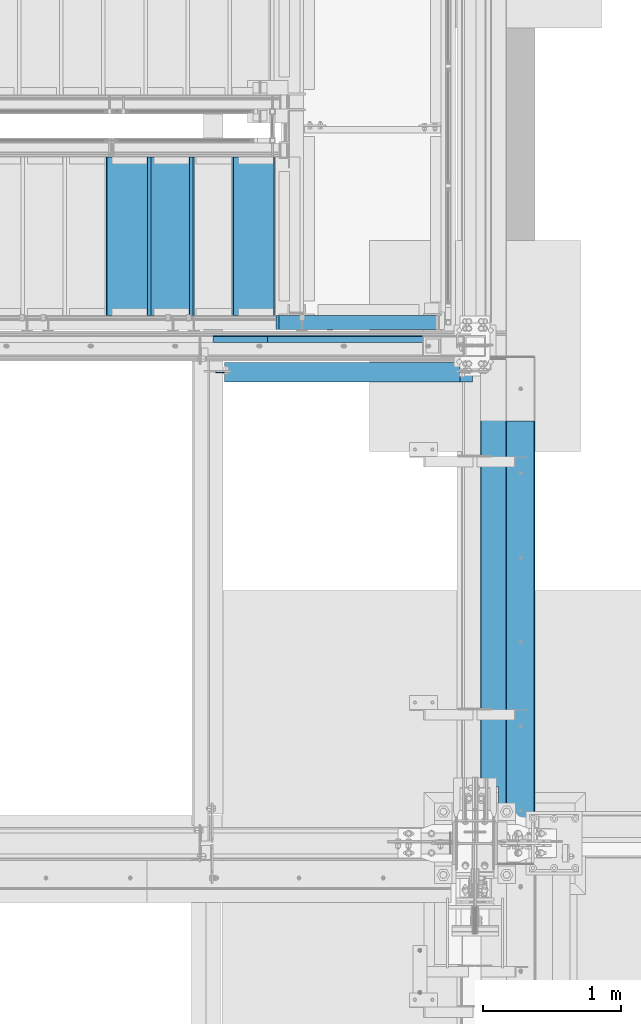
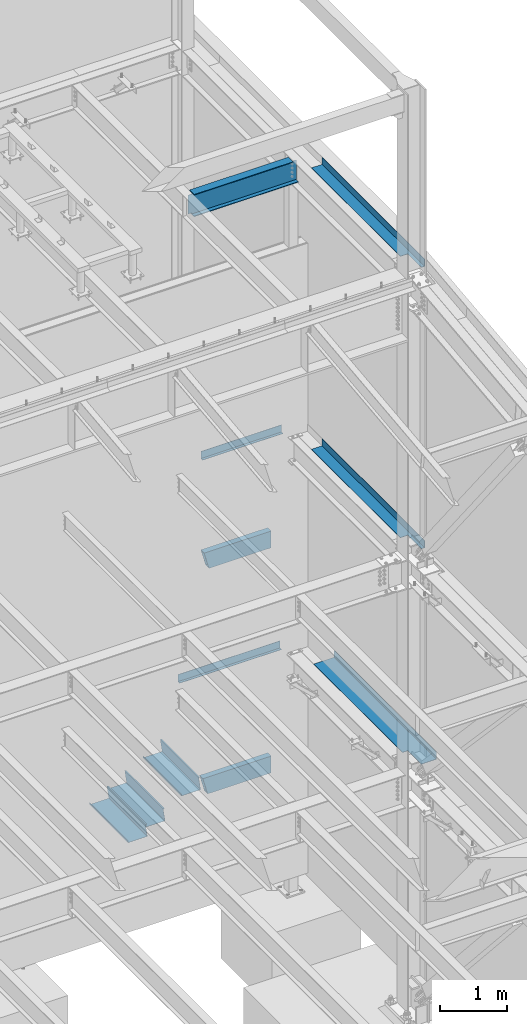
# One storey, part 785 of 1179: 11 beams, 8 elements without a shape of their own.
"""IFC2X3 building model written with IfcOpenShell, lengths in millimetres."""

from ifc_helpers import new_model, si_unit, frame, origin_with_axes, place, context, subcontext, project, spatial, faceted_brep, material, type_object, element, aggregate, save


model = new_model("IFC2X3")

# Units and contexts
model_context = context("Model", 3, precision=1e-05, world=origin_with_axes())
body_context = subcontext(model_context, "Body", "Model", "MODEL_VIEW")
ifc_project = project(units=[si_unit("LENGTHUNIT", "METRE", prefix="MILLI"), si_unit("AREAUNIT", "SQUARE_METRE"), si_unit("VOLUMEUNIT", "CUBIC_METRE"), si_unit("MASSUNIT", "GRAM", prefix="KILO"), si_unit("TIMEUNIT", "SECOND"), si_unit("PLANEANGLEUNIT", "RADIAN"), si_unit("SOLIDANGLEUNIT", "STERADIAN"), si_unit("THERMODYNAMICTEMPERATUREUNIT", "DEGREE_CELSIUS"), si_unit("LUMINOUSINTENSITYUNIT", "LUMEN")], contexts=[model_context])

# Site, building, storey
site_placement = place(None, origin_with_axes())
site = spatial("IfcSite", under=ifc_project, at=site_placement, CompositionType="ELEMENT")
building_placement = place(site_placement, origin_with_axes())
building = spatial("IfcBuilding", under=site, at=building_placement, Name="Undefined", CompositionType="ELEMENT")
storey_placement = place(building_placement, origin_with_axes())
storey = spatial("IfcBuildingStorey", under=building, at=storey_placement, Name="Undefined", CompositionType="ELEMENT", Elevation=0.0)

# Assembly, beam
assembly_1_placement = place(storey_placement, origin_with_axes())
assembly_1 = element("IfcElementAssembly", 1, at=assembly_1_placement, inside=storey, Name="BEAM", AssemblyPlace="NOTDEFINED", PredefinedType="RIGID_FRAME")
ifc_material_1 = material(Name="STEEL/A36")
beam_type_1 = type_object("IfcBeamType", PredefinedType="NOTDEFINED")
beam_1_placement = place(assembly_1_placement, frame((23498.175, 38058.725, 8147.05000610352), z_axis=(1.0, 0.0, 0.0), x_axis=(0.0, 0.0, -1.0)))
beam_1 = element("IfcBeam", 2, at=beam_1_placement, type_object=beam_type_1, material=ifc_material_1, Name="BENT_PLATE", context=body_context, shape_type="Brep", body=[
    faceted_brep([(0.0, -3.17500000000291, -688.974999999999), (0.0, -3.17500000000291, 688.974999999999), (0.0, 3.17500000000291, 688.974999999999), (0.0, 3.17500000000291, -688.974999999999), (133.350006103513, 3.17500000000291, 688.974999999999), (133.350006103513, 3.17500000000291, -688.974999999999), (127.000006103513, -3.17500000000291, -688.974999999999), (127.000006103513, -3.17500000000291, 688.974999999999), (133.350006103513, -47.6249999999927, 688.974999999999), (133.350006103513, -47.6249999999927, -688.974999999999), (127.000006103513, -47.6249999999927, 688.974999999999), (127.000006103513, -47.6249999999927, -688.974999999999)], [[[0, 1, 2, 3]], [[3, 2, 4, 5]], [[1, 0, 6, 7]], [[5, 4, 8, 9]], [[4, 2, 1, 7, 10, 8]], [[7, 6, 11, 10]], [[6, 0, 3, 5, 9, 11]], [[10, 11, 9, 8]]]),
])
aggregate(assembly_1, [beam_1])

assembly_2_placement = place(storey_placement, origin_with_axes())
assembly_2 = element("IfcElementAssembly", 3, at=assembly_2_placement, inside=storey, Name="BEAM", AssemblyPlace="NOTDEFINED", PredefinedType="RIGID_FRAME")
beam_2_placement = place(assembly_2_placement, frame((23290.2125, 38058.725, 4235.45000610352), z_axis=(1.0, 0.0, 0.0), x_axis=(0.0, 0.0, -1.0)))
beam_2 = element("IfcBeam", 4, at=beam_2_placement, type_object=beam_type_1, material=ifc_material_1, Name="BENT_PLATE", context=body_context, shape_type="Brep", body=[
    faceted_brep([(0.0, -3.17500000000291, -874.712500000001), (0.0, -3.17500000000291, 874.712500000001), (0.0, 3.17500000000291, 874.712500000001), (0.0, 3.17500000000291, -874.712500000001), (133.350006103513, 3.17500000000291, 874.712500000001), (133.350006103513, 3.17500000000291, -874.712500000001), (127.000006103513, -3.17500000000291, -874.712500000001), (127.000006103513, -3.17500000000291, 874.712500000001), (133.350006103513, -47.6249999999927, 874.712500000001), (133.350006103513, -47.6249999999927, -874.712500000001), (127.000006103513, -47.6249999999927, 874.712500000001), (127.000006103513, -47.6249999999927, -874.712500000001)], [[[0, 1, 2, 3]], [[3, 2, 4, 5]], [[1, 0, 6, 7]], [[5, 4, 8, 9]], [[4, 2, 1, 7, 10, 8]], [[7, 6, 11, 10]], [[6, 0, 3, 5, 9, 11]], [[10, 11, 9, 8]]]),
])
aggregate(assembly_2, [beam_2])

assembly_3_placement = place(storey_placement, origin_with_axes())
assembly_3 = element("IfcElementAssembly", 5, at=assembly_3_placement, inside=storey, Name="BEAM", AssemblyPlace="NOTDEFINED", PredefinedType="RIGID_FRAME")
ifc_material_2 = material(Name="STEEL/A992")
beam_type_2 = type_object("IfcBeamType", Name="W16X31", PredefinedType="NOTDEFINED")
beam_3_placement = place(assembly_3_placement, frame((22415.5, 37795.2, 12917.4875), z_axis=(0.0, 0.0, 1.0), x_axis=(1.0, 0.0, 0.0)))
beam_3 = element("IfcBeam", 6, at=beam_3_placement, type_object=beam_type_2, material=ifc_material_2, Name="BEAM", ObjectType="W16X31", context=body_context, shape_type="Brep", body=[
    faceted_brep([(1781.96875, -69.8499999999985, 201.612499999999), (1781.96875, -69.8499999999985, 190.5), (1781.96875, -3.17500000000291, 190.5), (1781.96875, -3.17500000000291, 176.212499809264), (1781.96875, 3.17500000000291, 176.212499809264), (1781.96875, 3.17500000000291, 190.5), (1781.96875, 69.8499999999985, 190.5), (1781.96875, 69.8499999999985, 201.612499999999), (1782.93547992258, -3.17500000000291, 171.352420291218), (1782.93547992258, 3.17500000000291, 171.352420291218), (1785.68849382306, -3.17500000000291, 167.232243823064), (1785.68849382306, 3.17500000000291, 167.232243823064), (1789.80867029122, -3.17500000000291, 164.479229922586), (1789.80867029122, 3.17500000000291, 164.479229922586), (1794.66874980926, -3.17500000000291, 163.512499999999), (1794.66874980926, 3.17500000000291, 163.512499999999), (1874.04375, -3.17500000000291, 163.512499999999), (1874.04375, 3.17500000000291, 163.512499999999), (82.549999999992, -69.8499999999985, 201.6125), (82.549999999992, 69.8499999999985, 201.6125), (82.549999999992, 69.8499999999985, 190.5), (82.549999999992, 3.17499999999927, 190.5), (82.549999999992, 3.17499999999927, 182.562499809265), (82.549999999992, -3.17499999999927, 182.562499809265), (82.549999999992, -3.17499999999927, 190.5), (82.549999999992, -69.8499999999985, 190.5), (81.5832700774044, 3.17499999999927, 177.70242029122), (81.5832700774044, -3.17499999999927, 177.70242029122), (78.8302561769269, 3.17499999999927, 173.582243823066), (78.8302561769269, -3.17499999999927, 173.582243823066), (74.7100797087733, 3.17499999999927, 170.829229922588), (74.7100797087733, -3.17499999999927, 170.829229922588), (69.8500001907269, 3.17499999999927, 169.8625), (69.8500001907269, -3.17499999999927, 169.8625), (15.875, 3.17499999999927, 169.8625), (15.875, -3.17499999999927, 169.8625), (15.875, 3.17499999999927, -169.8625), (15.875, -3.17499999999927, -169.8625), (69.8500001907269, 3.17499999999927, -169.8625), (69.8500001907269, -3.17499999999927, -169.8625), (74.7100797087733, 3.17499999999927, -170.829229922588), (74.7100797087733, -3.17499999999927, -170.829229922588), (78.8302561769269, 3.17499999999927, -173.582243823066), (78.8302561769269, -3.17499999999927, -173.582243823066), (81.5832700774044, 3.17499999999927, -177.70242029122), (81.5832700774044, -3.17499999999927, -177.70242029122), (82.549999999992, 3.17499999999927, -182.562499809265), (82.549999999992, -3.17499999999927, -182.562499809265), (82.549999999992, 69.8499999999985, -190.5), (82.549999999992, 3.17499999999927, -190.5), (1747.04375, 3.17500000000291, -190.5), (1747.04375, 69.8499999999985, -190.5), (82.549999999992, 69.8499999999985, -201.6125), (1747.04375, 69.8499999999985, -201.612499999999), (1747.04375, 3.17549991607666, -201.612499999999), (1874.04375, 3.17500000000291, -190.5), (1874.04375, 3.17549991607666, -201.612499999999), (1874.04375, -69.8499999999985, -201.612499999999), (82.549999999992, -69.8499999999985, -201.6125), (1874.04375, -69.8499999999985, -190.5), (82.549999999992, -69.8499999999985, -190.5), (82.549999999992, -3.17499999999927, -190.5), (1874.04375, -3.17500000000291, -190.5)], [[[0, 1, 2, 3, 4, 5, 6, 7]], [[8, 9, 4, 3]], [[10, 11, 9, 8]], [[12, 13, 11, 10]], [[14, 15, 13, 12]], [[16, 17, 15, 14]], [[18, 19, 20, 21, 22, 23, 24, 25]], [[23, 22, 26, 27]], [[27, 26, 28, 29]], [[29, 28, 30, 31]], [[31, 30, 32, 33]], [[33, 32, 34, 35]], [[35, 34, 36, 37]], [[37, 36, 38, 39]], [[39, 38, 40, 41]], [[41, 40, 42, 43]], [[43, 42, 44, 45]], [[45, 44, 46, 47]], [[48, 49, 50, 51]], [[52, 48, 51, 53]], [[50, 54, 53, 51]], [[55, 56, 54, 50]], [[57, 58, 52, 53, 54, 56]], [[57, 59, 60, 58]], [[47, 46, 49, 48, 52, 58, 60, 61]], [[59, 62, 61, 60]], [[12, 10, 8, 3, 2, 24, 23, 27, 29, 31, 33, 35, 37, 39, 41, 43, 45, 47, 61, 62, 16, 14]], [[25, 24, 2, 1]], [[18, 25, 1, 0]], [[19, 18, 0, 7]], [[20, 19, 7, 6]], [[21, 20, 6, 5]], [[55, 50, 49, 46, 44, 42, 40, 38, 36, 34, 32, 30, 28, 26, 22, 21, 5, 4, 9, 11, 13, 15, 17]], [[62, 59, 57, 56, 55, 17, 16]]]),
])
aggregate(assembly_3, [beam_3])

assembly_4_placement = place(storey_placement, origin_with_axes())
assembly_4 = element("IfcElementAssembly", 7, at=assembly_4_placement, inside=storey, Name="BEAM", AssemblyPlace="NOTDEFINED", PredefinedType="RIGID_FRAME")
beam_type_3 = type_object("IfcBeamType", PredefinedType="NOTDEFINED")
beam_4_placement = place(assembly_4_placement, frame((24350.663, 35921.95, 13122.275), z_axis=(0.0, -1.0, 0.0), x_axis=(1.0, 0.0, 0.0)))
beam_4 = element("IfcBeam", 8, at=beam_4_placement, type_object=beam_type_3, material=ifc_material_1, Name="BENT_PLATE", context=body_context, shape_type="Brep", body=[
    faceted_brep([(125.411500847065, -3.17499999999563, 1123.95), (125.411500847065, 3.17500000000473, 1123.95), (0.0, 3.17499999999927, 1123.95), (0.0, -3.17499999999927, 1123.95), (125.411500847065, -3.17499999999927, 1524.00000000024), (125.411500847065, 3.17499999999927, 1524.0), (185.737000201926, -3.17500000083055, -1523.99999999987), (0.0, -3.17499999999927, -1524.0), (0.0, 3.17499999999927, -1524.0), (179.387000201926, 3.17499999921893, -1523.99999999987), (179.387000000002, 130.175000000001, -1524.0), (185.737000000001, 130.175000000001, -1524.0), (179.387000203274, 3.1749999978274, 1523.9999999998), (179.387000000002, 130.175000000001, 1524.0), (185.737000000001, 130.175000000001, 1524.0), (185.737000203274, -3.17500000222026, 1523.9999999998)], [[[0, 1, 2, 3]], [[4, 5, 1, 0]], [[6, 7, 8, 9, 10, 11]], [[9, 12, 13, 10]], [[14, 11, 10, 13]], [[15, 6, 11, 14]], [[3, 7, 6, 15, 4, 0]], [[8, 7, 3, 2]], [[12, 9, 8, 2, 1, 5]], [[15, 14, 13, 12, 5, 4]]]),
])
aggregate(assembly_4, [beam_4])

assembly_5_placement = place(storey_placement, origin_with_axes())
assembly_5 = element("IfcElementAssembly", 9, at=assembly_5_placement, inside=storey, Name="STAIR", AssemblyPlace="NOTDEFINED", PredefinedType="RIGID_FRAME")
ifc_material_3 = material()
beam_type_4 = type_object("IfcBeamType", Name="HSS12X4X3/8", PredefinedType="NOTDEFINED")
beam_5_placement = place(assembly_5_placement, frame((22890.3259889477, 38157.1499999749, 6089.65000000013), z_axis=(0.0, 0.0, 1.0), x_axis=(1.0, 0.0, 0.0)))
beam_5 = element("IfcBeam", 10, at=beam_5_placement, type_object=beam_type_4, material=ifc_material_3, Name="STAIR", ObjectType="HSS12X4X3/8", context=body_context, shape_type="Brep", body=[
    faceted_brep([(79.827342666882, 41.2750000000015, -142.875), (79.827342666882, -41.2750000000015, -142.875), (1150.77401105232, -41.2750000000015, -142.875), (1150.77401105232, 41.2750000000015, -142.875), (2.57507555327538, -41.2750000000015, 142.875), (1150.77401105232, -41.2750000000015, 142.875), (2.57507555327538, 41.2750000000015, 142.875), (1150.77401105232, 41.2750000000015, 142.875), (82.402418237336, 50.8000000000029, -152.4), (0.0, 50.8000000000029, 152.4), (1150.77401105232, 50.8000000000029, 152.4), (1150.77401105232, 50.8000000000029, -152.4), (0.0, -50.8000000000029, 152.4), (1150.77401105232, -50.8000000000029, 152.4), (82.402418237336, -50.8000000000029, -152.4), (1150.77401105232, -50.8000000000029, -152.4)], [[[0, 1, 2, 3]], [[1, 4, 5, 2]], [[4, 6, 7, 5]], [[6, 0, 3, 7]], [[8, 9, 10, 11]], [[9, 12, 13, 10]], [[12, 14, 15, 13]], [[14, 8, 11, 15]], [[13, 15, 11, 10], [5, 7, 3, 2]], [[14, 12, 9, 8], [6, 4, 1, 0]]]),
])
aggregate(assembly_5, [beam_5])

# Assembly, beams
assembly_6_placement = place(storey_placement, origin_with_axes())
assembly_6 = element("IfcElementAssembly", 11, at=assembly_6_placement, inside=storey, Name="STAIR", AssemblyPlace="NOTDEFINED", PredefinedType="RIGID_FRAME")
beam_6_placement = place(assembly_6_placement, frame((22868.7619617943, 38157.1499999749, 2003.42499935032), z_axis=(0.0, 0.0, 1.0), x_axis=(1.0, 0.0, 0.0)))
beam_6 = element("IfcBeam", 12, at=beam_6_placement, type_object=beam_type_4, material=ifc_material_3, Name="STAIR", ObjectType="HSS12X4X3/8", context=body_context, shape_type="Brep", body=[
    faceted_brep([(79.3135518111412, 41.2750000000015, -142.875), (79.3135518111412, -41.2750000000015, -142.875), (1172.33803861999, -41.2750000000015, -142.875), (1172.33803861999, 41.2750000000015, -142.875), (2.55849975384263, -41.2750000000015, 142.875), (1172.33803861999, -41.2750000000015, 142.875), (2.55849975384263, 41.2750000000015, 142.875), (1172.33803861999, 41.2750000000015, 142.875), (81.8720535463835, 50.8000000000029, -152.4), (0.0, 50.8000000000029, 152.4), (1172.33803861999, 50.8000000000029, 152.4), (1172.33803861999, 50.8000000000029, -152.4), (0.0, -50.8000000000029, 152.4), (1172.33803861999, -50.8000000000029, 152.4), (81.8720535463835, -50.8000000000029, -152.4), (1172.33803861999, -50.8000000000029, -152.4)], [[[0, 1, 2, 3]], [[1, 4, 5, 2]], [[4, 6, 7, 5]], [[6, 0, 3, 7]], [[8, 9, 10, 11]], [[9, 12, 13, 10]], [[12, 14, 15, 13]], [[14, 8, 11, 15]], [[13, 15, 11, 10], [5, 7, 3, 2]], [[14, 12, 9, 8], [6, 4, 1, 0]]]),
])
beam_type_5 = type_object("IfcBeamType", PredefinedType="NOTDEFINED")
beam_7_placement = place(assembly_6_placement, frame((22269.4500003542, 38779.4500000263, 1763.48083279677), z_axis=(0.0, -1.0, 0.0), x_axis=(-1.0, 0.0, 0.0)))
beam_7 = element("IfcBeam", 13, at=beam_7_placement, type_object=beam_type_5, material=ifc_material_1, Name="TREAD", context=body_context, shape_type="Brep", body=[
    faceted_brep([(0.0, -1.28999999999996, -571.5), (0.0, -1.28999999999996, 571.5), (0.0, 1.28999999999996, 571.5), (0.0, 1.28999999999996, -571.5), (22.4220799334253, 1.28999999999996, 571.5), (22.4220799334253, 1.28999999999996, -571.5), (25.4000000000015, -1.28999999999996, -571.5), (25.4000000000015, -1.28999999999996, 571.5), (-10.2894642965184, 228.56708328371, 571.5), (-10.2894642965184, 228.56708328371, -571.5), (-7.31154422994223, 225.98708328371, -571.5), (-7.31154422994223, 225.98708328371, 571.5), (319.911141878769, 228.56708328371, 571.5), (319.911141878769, 228.56708328371, -571.5), (317.675890478069, 225.98708328371, -571.5), (317.675890478069, 225.98708328371, 571.5), (325.657303794516, 188.643229151176, 571.5), (325.657303794516, 188.643229151176, -571.5), (323.103618368372, 188.27568222317, 571.5), (323.103618368372, 188.27568222317, -571.5)], [[[0, 1, 2, 3]], [[3, 2, 4, 5]], [[1, 0, 6, 7]], [[5, 4, 8, 9]], [[7, 6, 10, 11]], [[9, 8, 12, 13]], [[11, 10, 14, 15]], [[13, 12, 16, 17]], [[12, 8, 4, 2, 1, 7, 11, 15, 18, 16]], [[15, 14, 19, 18]], [[14, 10, 6, 0, 3, 5, 9, 13, 17, 19]], [[18, 19, 17, 16]]]),
])
beam_8_placement = place(assembly_6_placement, frame((21964.6500003274, 38779.4500000276, 1587.00374951757), z_axis=(0.0, -1.0, 0.0), x_axis=(-1.0, 0.0, 0.0)))
beam_8 = element("IfcBeam", 14, at=beam_8_placement, type_object=beam_type_5, material=ifc_material_1, Name="TREAD", context=body_context, shape_type="Brep", body=[
    faceted_brep([(0.0, -1.28999999999996, -571.5), (0.0, -1.28999999999996, 571.5), (0.0, 1.28999999999996, 571.5), (0.0, 1.28999999999996, -571.5), (22.4220799334253, 1.28999999999996, 571.5), (22.4220799334253, 1.28999999999996, -571.5), (25.4000000000015, -1.28999999999996, -571.5), (25.4000000000015, -1.28999999999996, 571.5), (-10.2894642965184, 228.56708328371, 571.5), (-10.2894642965184, 228.56708328371, -571.5), (-7.31154422994223, 225.98708328371, -571.5), (-7.31154422994223, 225.98708328371, 571.5), (319.911141878769, 228.56708328371, 571.5), (319.911141878769, 228.56708328371, -571.5), (317.675890478069, 225.98708328371, -571.5), (317.675890478069, 225.98708328371, 571.5), (325.657303794516, 188.643229151176, 571.5), (325.657303794516, 188.643229151176, -571.5), (323.103618368372, 188.27568222317, 571.5), (323.103618368372, 188.27568222317, -571.5)], [[[0, 1, 2, 3]], [[3, 2, 4, 5]], [[1, 0, 6, 7]], [[5, 4, 8, 9]], [[7, 6, 10, 11]], [[9, 8, 12, 13]], [[11, 10, 14, 15]], [[13, 12, 16, 17]], [[12, 8, 4, 2, 1, 7, 11, 15, 18, 16]], [[15, 14, 19, 18]], [[14, 10, 6, 0, 3, 5, 9, 13, 17, 19]], [[18, 19, 17, 16]]]),
])
beam_9_placement = place(assembly_6_placement, frame((22879.0500004077, 38779.4500000238, 2116.43499935517), z_axis=(0.0, -1.0, 0.0), x_axis=(-1.0, 0.0, 0.0)))
beam_9 = element("IfcBeam", 15, at=beam_9_placement, type_object=beam_type_5, material=ifc_material_1, Name="TREAD", context=body_context, shape_type="Brep", body=[
    faceted_brep([(0.0, -1.28999999999996, -571.5), (0.0, -1.28999999999996, 571.5), (0.0, 1.28999999999996, 571.5), (0.0, 1.28999999999996, -571.5), (22.4220799334253, 1.28999999999996, 571.5), (22.4220799334253, 1.28999999999996, -571.5), (25.4000000000015, -1.28999999999996, -571.5), (25.4000000000015, -1.28999999999996, 571.5), (-10.2894642965184, 228.56708328371, 571.5), (-10.2894642965184, 228.56708328371, -571.5), (-7.31154422994223, 225.98708328371, -571.5), (-7.31154422994223, 225.98708328371, 571.5), (319.911141878769, 228.56708328371, 571.5), (319.911141878769, 228.56708328371, -571.5), (317.675890478069, 225.98708328371, -571.5), (317.675890478069, 225.98708328371, 571.5), (325.657303794516, 188.643229151176, 571.5), (325.657303794516, 188.643229151176, -571.5), (323.103618368372, 188.27568222317, 571.5), (323.103618368372, 188.27568222317, -571.5)], [[[0, 1, 2, 3]], [[3, 2, 4, 5]], [[1, 0, 6, 7]], [[5, 4, 8, 9]], [[7, 6, 10, 11]], [[9, 8, 12, 13]], [[11, 10, 14, 15]], [[13, 12, 16, 17]], [[12, 8, 4, 2, 1, 7, 11, 15, 18, 16]], [[15, 14, 19, 18]], [[14, 10, 6, 0, 3, 5, 9, 13, 17, 19]], [[18, 19, 17, 16]]]),
])
aggregate(assembly_6, [beam_7, beam_8, beam_9, beam_6])

# Assembly, beam
assembly_7_placement = place(storey_placement, origin_with_axes())
assembly_7 = element("IfcElementAssembly", 16, at=assembly_7_placement, inside=storey, Name="BEAM", AssemblyPlace="NOTDEFINED", PredefinedType="RIGID_FRAME")
beam_type_6 = type_object("IfcBeamType", PredefinedType="NOTDEFINED")
beam_10_placement = place(assembly_7_placement, frame((24347.4874938354, 35918.7749996833, 8016.875), z_axis=(0.0, 1.0, 0.0), x_axis=(1.0, 0.0, 0.0)))
beam_10 = element("IfcBeam", 17, at=beam_10_placement, type_object=beam_type_6, material=ifc_material_1, Name="BENT_PLATE", context=body_context, shape_type="Brep", body=[
    faceted_brep([(128.587506441512, -3.17499996052265, -1119.18749994072), (128.587506644712, 3.1750000394768, -1119.18749994072), (128.587505839529, 3.1750000394768, -1523.99999999988), (128.587505636329, -3.17499996052265, -1523.99999999988), (1.96814653463662e-09, -3.17500000000109, -1119.18749972653), (1.81898940354586e-11, 3.17499999999927, -1119.18749972653), (188.912503209351, 3.17500005799775, 1524.00000000017), (6.00266503170133e-10, 3.17500000077416, 1524.00000000052), (6.00266503170133e-10, -3.17499999922438, 1524.00000000052), (182.562503006164, -3.17499994395257, 1524.00000000017), (182.562498942389, -130.175012106998, 1524.00000000017), (188.912498942391, -130.175012310187, 1524.00000000017), (188.912503212043, 3.17500005799775, -1523.99999999983), (188.912498945083, -130.175012310187, -1523.99999999983), (182.562498945081, -130.175012106998, -1523.99999999983), (182.562503008856, -3.17499994395257, -1523.99999999983)], [[[0, 1, 2, 3]], [[4, 5, 1, 0]], [[6, 7, 8, 9, 10, 11]], [[12, 6, 11, 13]], [[10, 14, 13, 11]], [[9, 15, 14, 10]], [[12, 13, 14, 15, 3, 2]], [[7, 6, 12, 2, 1, 5]], [[8, 7, 5, 4]], [[15, 9, 8, 4, 0, 3]]]),
])
aggregate(assembly_7, [beam_10])

assembly_8_placement = place(storey_placement, origin_with_axes())
assembly_8 = element("IfcElementAssembly", 18, at=assembly_8_placement, inside=storey, Name="BEAM", AssemblyPlace="NOTDEFINED", PredefinedType="RIGID_FRAME")
beam_type_7 = type_object("IfcBeamType", PredefinedType="NOTDEFINED")
beam_11_placement = place(assembly_8_placement, frame((24387.175012207, 35918.775, 4105.275), z_axis=(0.0, -1.0, 0.0), x_axis=(1.0, 0.0, 0.0)))
beam_11 = element("IfcBeam", 19, at=beam_11_placement, type_object=beam_type_7, material=ifc_material_1, Name="BENT_PLATE", context=body_context, shape_type="Brep", body=[
    faceted_brep([(88.8999862670898, -3.17500000000018, 1119.98125), (88.8999862670898, 3.17500000000018, 1119.98125), (0.0, 3.17500000000018, 1119.98125), (0.0, -3.17500000000018, 1119.98125), (88.8999862670898, -3.17500000000018, 1524.0), (88.8999862670898, 3.17500000000018, 1524.0), (352.424987792969, -3.17499999999927, -1524.0), (0.0, -3.17499999999927, -1524.0), (0.0, 3.17499999999927, -1524.0), (346.07498779297, 3.17500000000109, -1524.0), (346.07498779297, 130.175006103515, -1524.0), (352.424987792969, 130.175006103515, -1524.0), (346.07498779297, 3.17500000000109, 1524.0), (346.07498779297, 130.175006103515, 1524.0), (352.424987792969, 130.175006103515, 1524.0), (352.424987792969, -3.17499999999927, 1524.0)], [[[0, 1, 2, 3]], [[4, 5, 1, 0]], [[6, 7, 8, 9, 10, 11]], [[9, 12, 13, 10]], [[14, 11, 10, 13]], [[15, 6, 11, 14]], [[3, 7, 6, 15, 4, 0]], [[8, 7, 3, 2]], [[12, 9, 8, 2, 1, 5]], [[15, 14, 13, 12, 5, 4]]]),
])
aggregate(assembly_8, [beam_11])

save(model, "model.ifc")
